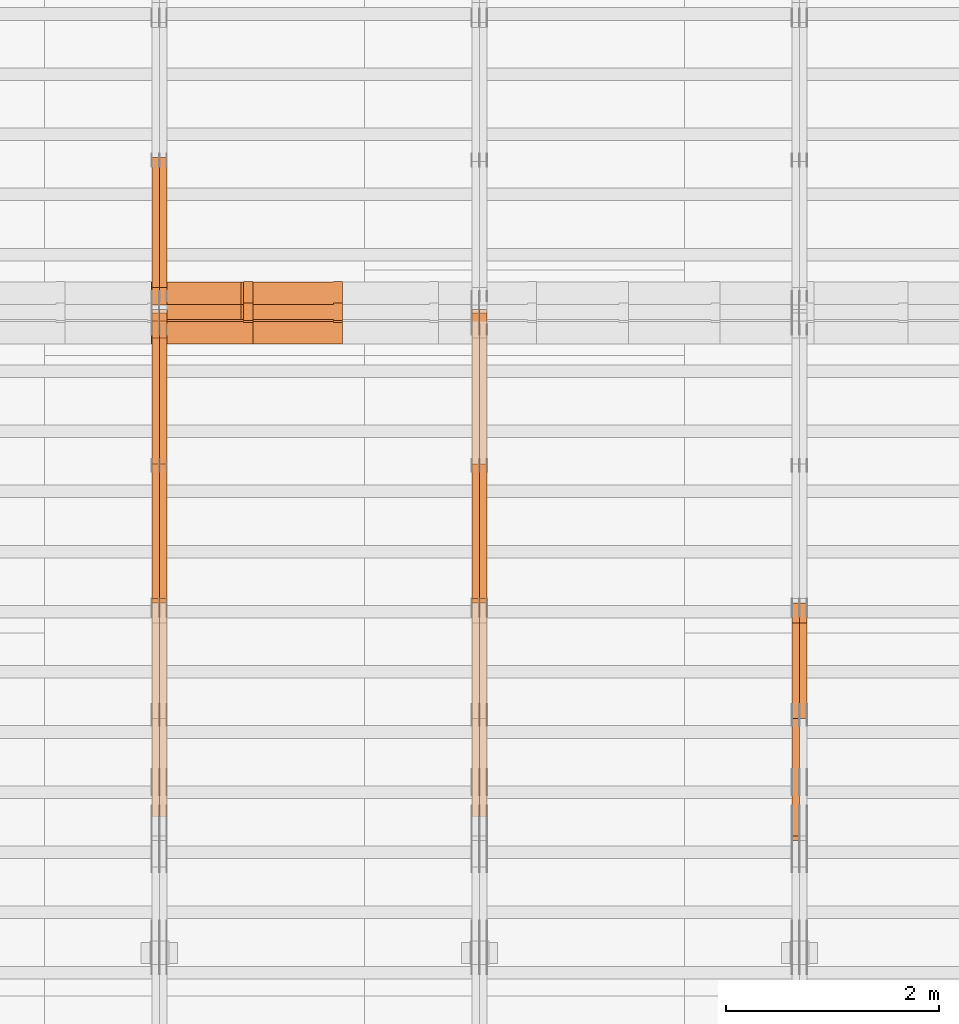
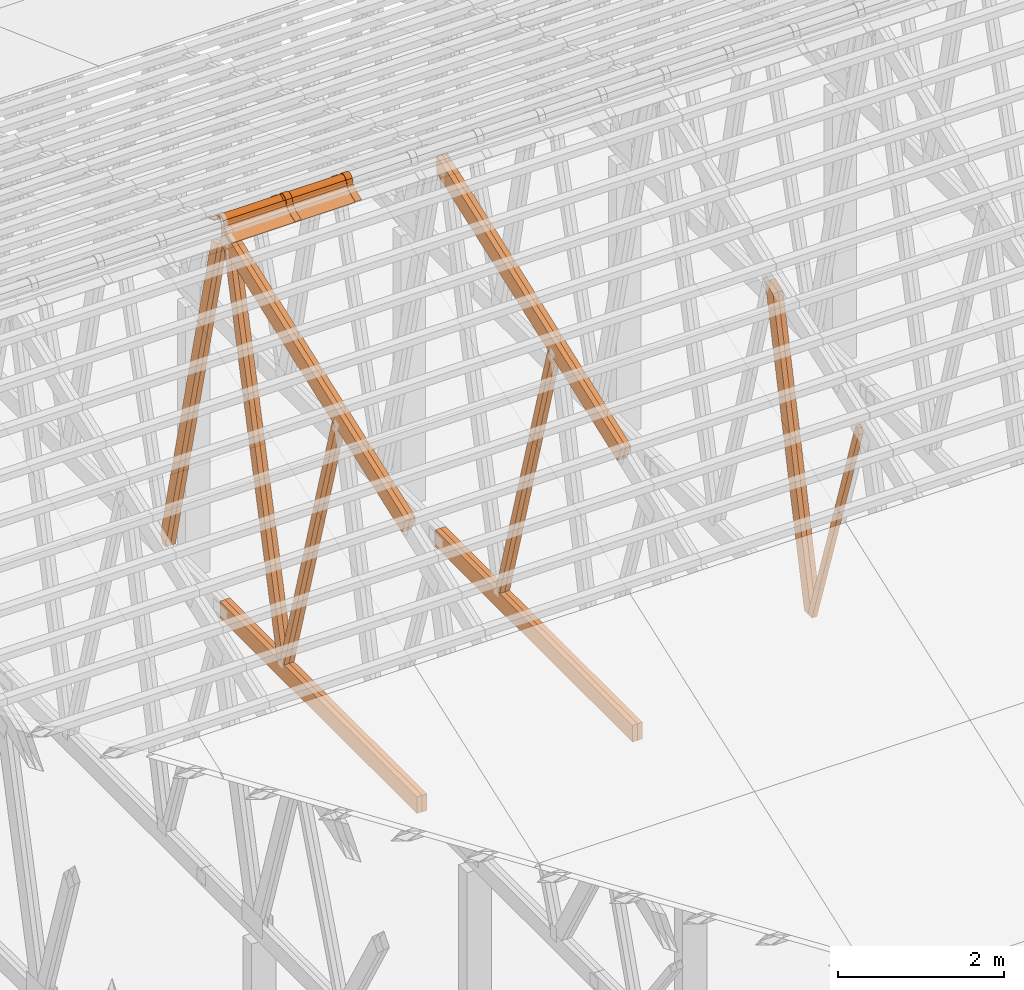
# One storey, part 26 of 189: 23 proxies.
"""IFC2X3 building model written with IfcOpenShell, lengths in millimetres."""

from ifc_helpers import new_model, entity, si_unit, converted_unit, derived_unit, direction, frame, frame_2d, origin, origin_2d_with_axis, place, context, subcontext, project, spatial, polyline, circle_curve, parameter, trimmed, segment, composite_curve, rectangle, outline, extrude, source, transform, mapped, material, type_object, type_shapes, element, save


model = new_model("IFC2X3")

# Units and contexts
model_context = context("Model", 3, precision=0.01, world=origin(), true_north=direction((6.12303176911189e-17, 1.0)))
body_context = subcontext(model_context, "Body", "Model", "MODEL_VIEW")
ifc_project = project(units=[si_unit("LENGTHUNIT", "METRE", prefix="MILLI"), si_unit("AREAUNIT", "SQUARE_METRE"), si_unit("VOLUMEUNIT", "CUBIC_METRE"), converted_unit("PLANEANGLEUNIT", "DEGREE", entity("IfcRatioMeasure", 0.0174532925199433), si_unit("PLANEANGLEUNIT", "RADIAN"), dimensions=[0, 0, 0, 0, 0, 0, 0]), si_unit("MASSUNIT", "GRAM", prefix="KILO"), derived_unit("MASSDENSITYUNIT", [(si_unit("MASSUNIT", "GRAM", prefix="KILO"), 1), (si_unit("LENGTHUNIT", "METRE"), -3)]), si_unit("TIMEUNIT", "SECOND"), si_unit("FREQUENCYUNIT", "HERTZ"), si_unit("THERMODYNAMICTEMPERATUREUNIT", "DEGREE_CELSIUS"), derived_unit("THERMALTRANSMITTANCEUNIT", [(si_unit("MASSUNIT", "GRAM", prefix="KILO"), 1), (si_unit("THERMODYNAMICTEMPERATUREUNIT", "KELVIN"), -1), (si_unit("TIMEUNIT", "SECOND"), -3)]), derived_unit("VOLUMETRICFLOWRATEUNIT", [(si_unit("LENGTHUNIT", "METRE"), 3), (si_unit("TIMEUNIT", "SECOND"), -1)]), si_unit("ELECTRICCURRENTUNIT", "AMPERE"), si_unit("ELECTRICVOLTAGEUNIT", "VOLT"), si_unit("POWERUNIT", "WATT"), si_unit("FORCEUNIT", "NEWTON"), si_unit("ILLUMINANCEUNIT", "LUX"), si_unit("LUMINOUSFLUXUNIT", "LUMEN"), si_unit("LUMINOUSINTENSITYUNIT", "CANDELA"), derived_unit("USERDEFINED", [(si_unit("MASSUNIT", "GRAM", prefix="KILO"), -1), (si_unit("LENGTHUNIT", "METRE"), -2), (si_unit("TIMEUNIT", "SECOND"), 3), (si_unit("LUMINOUSFLUXUNIT", "LUMEN"), 1)]), derived_unit("LINEARVELOCITYUNIT", [(si_unit("LENGTHUNIT", "METRE"), 1), (si_unit("TIMEUNIT", "SECOND"), -1)]), si_unit("PRESSUREUNIT", "PASCAL"), derived_unit("USERDEFINED", [(si_unit("LENGTHUNIT", "METRE"), -2), (si_unit("MASSUNIT", "GRAM", prefix="KILO"), 1), (si_unit("TIMEUNIT", "SECOND"), -2)])], contexts=[model_context])

# Site, building, storey
site_placement = place(None, origin())
site = spatial("IfcSite", under=ifc_project, at=site_placement, CompositionType="ELEMENT")
building_placement = place(site_placement, origin())
building = spatial("IfcBuilding", under=site, at=building_placement, CompositionType="ELEMENT")
storey_placement = place(building_placement, origin())
storey = spatial("IfcBuildingStorey", under=building, at=storey_placement, Name="Default", CompositionType="ELEMENT", Elevation=0.0)

# Proxies
ifc_material_1 = material(Name="IfcSurfaceStyle #115476")
building_element_proxy_type_1 = type_object("IfcBuildingElementProxyType", Name="T1-W3 115474", PredefinedType="NOTDEFINED", material=ifc_material_1)
shared_shape_1 = source(origin(), body_context, "Body", "SweptSolid", [
    extrude(outline(polyline([(-2625.55080717397, -84.9998286237256), (1749.48871563991, -84.9998286237256), (1768.20584427244, 0.000602085469291858), (1625.445846867, 85.0000405971208), (-2517.58959960538, 84.9990145648612), (-2625.55080717397, -84.9998286237256)])), frame((1768.20584427244, 85.0000405971208, 0.0), z_axis=(0.0, 0.0, 1.0), x_axis=(-1.0, 0.0, 0.0)), (0.0, 0.0, 1.0), 69.9999999999997),
])
type_shapes(building_element_proxy_type_1, [shared_shape_1])
proxy_1_placement = place(building_placement, frame((21300.0, 10918.6728403286, 263.278932236374), z_axis=(-1.0, 0.0, 0.0), x_axis=(0.0, 0.215047682154604, 0.976603550269982)))
element("IfcBuildingElementProxy", 1, at=proxy_1_placement, inside=storey, type_object=building_element_proxy_type_1, material=ifc_material_1, Name="T1-W3", context=body_context, shape_type="MappedRepresentation", body=[
    mapped(shared_shape_1, transform((0.0, 0.0, 0.0), scale=1.0)),
])
ifc_material_2 = material(Name="IfcSurfaceStyle #115410")
building_element_proxy_type_2 = type_object("IfcBuildingElementProxyType", Name="T1-W3 115408", PredefinedType="NOTDEFINED", material=ifc_material_2)
shared_shape_2 = source(origin(), body_context, "Body", "SweptSolid", [
    extrude(outline(polyline([(-2625.55080717397, -84.9998286237256), (1749.48871563991, -84.9998286237256), (1768.20584427244, 0.000602085469291858), (1625.445846867, 85.0000405971208), (-2517.58959960538, 84.9990145648612), (-2625.55080717397, -84.9998286237256)])), frame((1768.20584427244, 85.0000405971208, 0.0), z_axis=(0.0, 0.0, 1.0), x_axis=(-1.0, 0.0, 0.0)), (0.0, 0.0, 1.0), 69.9999999999997),
])
type_shapes(building_element_proxy_type_2, [shared_shape_2])
proxy_2_placement = place(building_placement, frame((21230.0, 10918.6728403286, 263.278932236374), z_axis=(-1.0, 0.0, 0.0), x_axis=(0.0, 0.215047682154604, 0.976603550269982)))
element("IfcBuildingElementProxy", 2, at=proxy_2_placement, inside=storey, type_object=building_element_proxy_type_2, material=ifc_material_2, Name="T1-W3", context=body_context, shape_type="MappedRepresentation", body=[
    mapped(shared_shape_2, transform((0.0, 0.0, 0.0), scale=1.0)),
])
ifc_material_3 = material(Name="IfcSurfaceStyle #115146")
building_element_proxy_type_3 = type_object("IfcBuildingElementProxyType", Name="T1-W7 115144", PredefinedType="NOTDEFINED", material=ifc_material_3)
shared_shape_3 = source(origin(), body_context, "Body", "SweptSolid", [
    extrude(outline(polyline([(-2158.15323194511, -47.5001976605119), (1398.58481981178, -47.5001976605119), (1473.93376219819, -0.000131511554346808), (1475.30069254941, 47.5002634162891), (-2189.66604261427, 47.5002634162891), (-2158.15323194511, -47.5001976605119)])), frame((1475.30069254941, 47.5002634162891, 0.0), z_axis=(0.0, 0.0, 1.0), x_axis=(-1.0, 0.0, 0.0)), (0.0, 0.0, 1.0), 69.9999999999998),
])
type_shapes(building_element_proxy_type_3, [shared_shape_3])
proxy_3_placement = place(building_placement, frame((21230.0, 9847.787109375, 3723.57788085937), z_axis=(-1.0, 0.0, 0.0), x_axis=(0.0, 0.314845237923105, -0.949143021971475)))
element("IfcBuildingElementProxy", 3, at=proxy_3_placement, inside=storey, type_object=building_element_proxy_type_3, material=ifc_material_3, Name="T1-W7", context=body_context, shape_type="MappedRepresentation", body=[
    mapped(shared_shape_3, transform((0.0, 0.0, 0.0), scale=1.0)),
])
ifc_material_4 = material(Name="IfcSurfaceStyle #99950")
building_element_proxy_type_4 = type_object("IfcBuildingElementProxyType", Name="T1-W6 99948", PredefinedType="NOTDEFINED", material=ifc_material_4)
shared_shape_4 = source(origin(), body_context, "Body", "SweptSolid", [
    extrude(outline(polyline([(-2640.84340836012, -47.4996765865792), (1711.12245024294, -47.4996765865792), (1797.68490303083, -9.57690019346202e-05), (1800.72595169379, 47.4997244710801), (-2668.68989660745, 47.4997244710801), (-2640.84340836012, -47.4996765865792)])), frame((1800.72595169379, 47.5003009358159, 0.0), z_axis=(0.0, 0.0, 1.0), x_axis=(-1.0, 0.0, 0.0)), (0.0, 0.0, 1.0), 69.9999999999997),
])
type_shapes(building_element_proxy_type_4, [shared_shape_4])
proxy_4_placement = place(building_placement, frame((18300.0, 12074.2896156894, 4533.9586582452), z_axis=(-1.0, 0.0, 0.0), x_axis=(0.0, 0.28128598310461, -0.959623986626467)))
element("IfcBuildingElementProxy", 4, at=proxy_4_placement, inside=storey, type_object=building_element_proxy_type_4, material=ifc_material_4, Name="T1-W6", context=body_context, shape_type="MappedRepresentation", body=[
    mapped(shared_shape_4, transform((0.0, 0.0, 0.0), scale=1.0)),
])
ifc_material_5 = material(Name="IfcSurfaceStyle #99884")
building_element_proxy_type_5 = type_object("IfcBuildingElementProxyType", Name="T1-W6 99882", PredefinedType="NOTDEFINED", material=ifc_material_5)
shared_shape_5 = source(origin(), body_context, "Body", "SweptSolid", [
    extrude(outline(polyline([(-2640.84340836012, -47.4996765865792), (1711.12245024294, -47.4996765865792), (1797.68490303083, -9.57690019346202e-05), (1800.72595169379, 47.4997244710801), (-2668.68989660745, 47.4997244710801), (-2640.84340836012, -47.4996765865792)])), frame((1800.72595169379, 47.5003009358159, 0.0), z_axis=(0.0, 0.0, 1.0), x_axis=(-1.0, 0.0, 0.0)), (0.0, 0.0, 1.0), 69.9999999999997),
])
type_shapes(building_element_proxy_type_5, [shared_shape_5])
proxy_5_placement = place(building_placement, frame((18230.0, 12074.2896156894, 4533.9586582452), z_axis=(-1.0, 0.0, 0.0), x_axis=(0.0, 0.28128598310461, -0.959623986626467)))
element("IfcBuildingElementProxy", 5, at=proxy_5_placement, inside=storey, type_object=building_element_proxy_type_5, material=ifc_material_5, Name="T1-W6", context=body_context, shape_type="MappedRepresentation", body=[
    mapped(shared_shape_5, transform((0.0, 0.0, 0.0), scale=1.0)),
])
ifc_material_6 = material(Name="IfcSurfaceStyle #95930")
building_element_proxy_type_6 = type_object("IfcBuildingElementProxyType", Name="T1-B3 95928", PredefinedType="NOTDEFINED", material=ifc_material_6)
shared_shape_6 = source(origin(), body_context, "Body", "SweptSolid", [
    extrude(rectangle(XDim=4751.0283203125, YDim=245.000000000001, at=origin_2d_with_axis()), frame((2375.51416015625, 122.5, 0.0), z_axis=(0.0, 0.0, 1.0), x_axis=(-1.0, 0.0, 0.0)), (0.0, 0.0, 1.0), 69.9999999999997),
])
type_shapes(building_element_proxy_type_6, [shared_shape_6])
proxy_6_placement = place(building_placement, frame((18300.0, 10029.23046875, 245.0), z_axis=(-1.0, 0.0, 0.0), x_axis=(0.0, 1.0, 0.0)))
element("IfcBuildingElementProxy", 6, at=proxy_6_placement, inside=storey, type_object=building_element_proxy_type_6, material=ifc_material_6, Name="T1-B3", context=body_context, shape_type="MappedRepresentation", body=[
    mapped(shared_shape_6, transform((0.0, 0.0, 0.0), scale=1.0)),
])
ifc_material_7 = material(Name="IfcSurfaceStyle #95873")
building_element_proxy_type_7 = type_object("IfcBuildingElementProxyType", Name="T1-B3 95871", PredefinedType="NOTDEFINED", material=ifc_material_7)
shared_shape_7 = source(origin(), body_context, "Body", "SweptSolid", [
    extrude(rectangle(XDim=4751.0283203125, YDim=245.000000000001, at=origin_2d_with_axis()), frame((2375.51416015625, 122.5, 0.0), z_axis=(0.0, 0.0, 1.0), x_axis=(-1.0, 0.0, 0.0)), (0.0, 0.0, 1.0), 69.9999999999997),
])
type_shapes(building_element_proxy_type_7, [shared_shape_7])
proxy_7_placement = place(building_placement, frame((18230.0, 10029.23046875, 245.0), z_axis=(-1.0, 0.0, 0.0), x_axis=(0.0, 1.0, 0.0)))
element("IfcBuildingElementProxy", 7, at=proxy_7_placement, inside=storey, type_object=building_element_proxy_type_7, material=ifc_material_7, Name="T1-B3", context=body_context, shape_type="MappedRepresentation", body=[
    mapped(shared_shape_7, transform((0.0, 0.0, 0.0), scale=1.0)),
])
ifc_material_8 = material(Name="IfcSurfaceStyle #95342")
building_element_proxy_type_8 = type_object("IfcBuildingElementProxyType", Name="T1-T3 95340", PredefinedType="NOTDEFINED", material=ifc_material_8)
shared_shape_8 = source(origin(), body_context, "Body", "SweptSolid", [
    extrude(outline(polyline([(-2341.64890001385, -122.499972785692), (2386.23525922045, -122.499972785692), (2297.06252495753, 122.499972785692), (-2341.64888416412, 122.499972785692), (-2341.64890001385, -122.499972785692)])), frame((2386.23525922045, 122.499973888764, 0.0), z_axis=(0.0, 0.0, 1.0), x_axis=(-1.0, 0.0, 0.0)), (0.0, 0.0, 1.0), 69.9999999999997),
])
type_shapes(building_element_proxy_type_8, [shared_shape_8])
proxy_8_placement = place(building_placement, frame((18300.0, 14833.7949607394, 5538.33627266055), z_axis=(-1.0, 0.0, 0.0), x_axis=(0.0, -0.939692620785908, -0.342020143325669)))
element("IfcBuildingElementProxy", 8, at=proxy_8_placement, inside=storey, type_object=building_element_proxy_type_8, material=ifc_material_8, Name="T1-T3", context=body_context, shape_type="MappedRepresentation", body=[
    mapped(shared_shape_8, transform((0.0, 0.0, 0.0), scale=1.0)),
])
ifc_material_9 = material(Name="IfcSurfaceStyle #95285")
building_element_proxy_type_9 = type_object("IfcBuildingElementProxyType", Name="T1-T3 95283", PredefinedType="NOTDEFINED", material=ifc_material_9)
shared_shape_9 = source(origin(), body_context, "Body", "SweptSolid", [
    extrude(outline(polyline([(-2341.64890001385, -122.499972785692), (2386.23525922045, -122.499972785692), (2297.06252495753, 122.499972785692), (-2341.64888416412, 122.499972785692), (-2341.64890001385, -122.499972785692)])), frame((2386.23525922045, 122.499973888764, 0.0), z_axis=(0.0, 0.0, 1.0), x_axis=(-1.0, 0.0, 0.0)), (0.0, 0.0, 1.0), 69.9999999999997),
])
type_shapes(building_element_proxy_type_9, [shared_shape_9])
proxy_9_placement = place(building_placement, frame((18230.0, 14833.7949607394, 5538.33627266055), z_axis=(-1.0, 0.0, 0.0), x_axis=(0.0, -0.939692620785908, -0.342020143325669)))
element("IfcBuildingElementProxy", 9, at=proxy_9_placement, inside=storey, type_object=building_element_proxy_type_9, material=ifc_material_9, Name="T1-T3", context=body_context, shape_type="MappedRepresentation", body=[
    mapped(shared_shape_9, transform((0.0, 0.0, 0.0), scale=1.0)),
])
ifc_material_10 = material(Name="IfcSurfaceStyle #84424")
building_element_proxy_type_10 = type_object("IfcBuildingElementProxyType", Name="T1-W5 84422", PredefinedType="NOTDEFINED", material=ifc_material_10)
shared_shape_10 = source(origin(), body_context, "Body", "SweptSolid", [
    extrude(outline(polyline([(-3233.61216530572, -72.4999091305202), (2153.79187521892, -72.4999091305202), (2171.36968478227, -7.18521572819375e-05), (2045.62106208646, 72.4999450565989), (-3137.17045678193, 72.4999450565989), (-3233.61216530572, -72.4999091305202)])), frame((2171.36968478227, 72.500192121173, 0.0), z_axis=(0.0, 0.0, 1.0), x_axis=(-1.0, 0.0, 0.0)), (0.0, 0.0, 1.0), 69.9999999999997),
])
type_shapes(building_element_proxy_type_10, [shared_shape_10])
proxy_10_placement = place(building_placement, frame((15300.0, 13261.0146935344, 262.082919891325), z_axis=(-1.0, 0.0, 0.0), x_axis=(0.0, 0.235625623344066, 0.97184389982328)))
element("IfcBuildingElementProxy", 10, at=proxy_10_placement, inside=storey, type_object=building_element_proxy_type_10, material=ifc_material_10, Name="T1-W5", context=body_context, shape_type="MappedRepresentation", body=[
    mapped(shared_shape_10, transform((0.0, 0.0, 0.0), scale=1.0)),
])
ifc_material_11 = material(Name="IfcSurfaceStyle #84358")
building_element_proxy_type_11 = type_object("IfcBuildingElementProxyType", Name="T1-W5 84356", PredefinedType="NOTDEFINED", material=ifc_material_11)
shared_shape_11 = source(origin(), body_context, "Body", "SweptSolid", [
    extrude(outline(polyline([(-3233.61216530572, -72.4999091305202), (2153.79187521892, -72.4999091305202), (2171.36968478227, -7.18521572819375e-05), (2045.62106208646, 72.4999450565989), (-3137.17045678193, 72.4999450565989), (-3233.61216530572, -72.4999091305202)])), frame((2171.36968478227, 72.500192121173, 0.0), z_axis=(0.0, 0.0, 1.0), x_axis=(-1.0, 0.0, 0.0)), (0.0, 0.0, 1.0), 69.9999999999997),
])
type_shapes(building_element_proxy_type_11, [shared_shape_11])
proxy_11_placement = place(building_placement, frame((15230.0, 13261.0146935344, 262.082919891325), z_axis=(-1.0, 0.0, 0.0), x_axis=(0.0, 0.235625623344066, 0.97184389982328)))
element("IfcBuildingElementProxy", 11, at=proxy_11_placement, inside=storey, type_object=building_element_proxy_type_11, material=ifc_material_11, Name="T1-W5", context=body_context, shape_type="MappedRepresentation", body=[
    mapped(shared_shape_11, transform((0.0, 0.0, 0.0), scale=1.0)),
])
ifc_material_12 = material(Name="IfcSurfaceStyle #84292")
building_element_proxy_type_12 = type_object("IfcBuildingElementProxyType", Name="T1-W5 84290", PredefinedType="NOTDEFINED", material=ifc_material_12)
shared_shape_12 = source(origin(), body_context, "Body", "SweptSolid", [
    extrude(outline(polyline([(-3137.17045678193, -72.5002081306407), (2045.62106208646, -72.5002081306408), (2171.36968478227, 5.58426931168476e-05), (2153.79187521892, 72.5001802092942), (-3233.61216530572, 72.5001802092942), (-3137.17045678193, -72.5002081306407)])), frame((2171.36968478227, 72.5001802092942, 0.0), z_axis=(0.0, 0.0, 1.0), x_axis=(-1.0, 0.0, 0.0)), (0.0, 0.0, 1.0), 69.9999999999997),
])
type_shapes(building_element_proxy_type_12, [shared_shape_12])
proxy_12_placement = place(building_placement, frame((15300.0, 16098.0675635854, 227.917113003597), z_axis=(-1.0, 0.0, 0.0), x_axis=(0.0, -0.235625623344066, 0.971843899823279)))
element("IfcBuildingElementProxy", 12, at=proxy_12_placement, inside=storey, type_object=building_element_proxy_type_12, material=ifc_material_12, Name="T1-W5", context=body_context, shape_type="MappedRepresentation", body=[
    mapped(shared_shape_12, transform((0.0, 0.0, 0.0), scale=1.0)),
])
ifc_material_13 = material(Name="IfcSurfaceStyle #84226")
building_element_proxy_type_13 = type_object("IfcBuildingElementProxyType", Name="T1-W5 84224", PredefinedType="NOTDEFINED", material=ifc_material_13)
shared_shape_13 = source(origin(), body_context, "Body", "SweptSolid", [
    extrude(outline(polyline([(-3137.17045678193, -72.5002081306407), (2045.62106208646, -72.5002081306408), (2171.36968478227, 5.58426931168476e-05), (2153.79187521892, 72.5001802092942), (-3233.61216530572, 72.5001802092942), (-3137.17045678193, -72.5002081306407)])), frame((2171.36968478227, 72.5001802092942, 0.0), z_axis=(0.0, 0.0, 1.0), x_axis=(-1.0, 0.0, 0.0)), (0.0, 0.0, 1.0), 69.9999999999997),
])
type_shapes(building_element_proxy_type_13, [shared_shape_13])
proxy_13_placement = place(building_placement, frame((15230.0, 16098.0675635854, 227.917113003597), z_axis=(-1.0, 0.0, 0.0), x_axis=(0.0, -0.235625623344066, 0.971843899823279)))
element("IfcBuildingElementProxy", 13, at=proxy_13_placement, inside=storey, type_object=building_element_proxy_type_13, material=ifc_material_13, Name="T1-W5", context=body_context, shape_type="MappedRepresentation", body=[
    mapped(shared_shape_13, transform((0.0, 0.0, 0.0), scale=1.0)),
])
ifc_material_14 = material(Name="IfcSurfaceStyle #84160")
building_element_proxy_type_14 = type_object("IfcBuildingElementProxyType", Name="T1-W6 84158", PredefinedType="NOTDEFINED", material=ifc_material_14)
shared_shape_14 = source(origin(), body_context, "Body", "SweptSolid", [
    extrude(outline(polyline([(-2640.84340836012, -47.4996765865792), (1711.12245024294, -47.4996765865792), (1797.68490303083, -9.57690019346202e-05), (1800.72595169379, 47.4997244710801), (-2668.68989660745, 47.4997244710801), (-2640.84340836012, -47.4996765865792)])), frame((1800.72595169379, 47.5003009358159, 0.0), z_axis=(0.0, 0.0, 1.0), x_axis=(-1.0, 0.0, 0.0)), (0.0, 0.0, 1.0), 69.9999999999997),
])
type_shapes(building_element_proxy_type_14, [shared_shape_14])
proxy_14_placement = place(building_placement, frame((15300.0, 12074.2896156894, 4533.9586582452), z_axis=(-1.0, 0.0, 0.0), x_axis=(0.0, 0.28128598310461, -0.959623986626467)))
element("IfcBuildingElementProxy", 14, at=proxy_14_placement, inside=storey, type_object=building_element_proxy_type_14, material=ifc_material_14, Name="T1-W6", context=body_context, shape_type="MappedRepresentation", body=[
    mapped(shared_shape_14, transform((0.0, 0.0, 0.0), scale=1.0)),
])
ifc_material_15 = material(Name="IfcSurfaceStyle #84094")
building_element_proxy_type_15 = type_object("IfcBuildingElementProxyType", Name="T1-W6 84092", PredefinedType="NOTDEFINED", material=ifc_material_15)
shared_shape_15 = source(origin(), body_context, "Body", "SweptSolid", [
    extrude(outline(polyline([(-2640.84340836012, -47.4996765865792), (1711.12245024294, -47.4996765865792), (1797.68490303083, -9.57690019346202e-05), (1800.72595169379, 47.4997244710801), (-2668.68989660745, 47.4997244710801), (-2640.84340836012, -47.4996765865792)])), frame((1800.72595169379, 47.5003009358159, 0.0), z_axis=(0.0, 0.0, 1.0), x_axis=(-1.0, 0.0, 0.0)), (0.0, 0.0, 1.0), 69.9999999999997),
])
type_shapes(building_element_proxy_type_15, [shared_shape_15])
proxy_15_placement = place(building_placement, frame((15230.0, 12074.2896156894, 4533.9586582452), z_axis=(-1.0, 0.0, 0.0), x_axis=(0.0, 0.28128598310461, -0.959623986626467)))
element("IfcBuildingElementProxy", 15, at=proxy_15_placement, inside=storey, type_object=building_element_proxy_type_15, material=ifc_material_15, Name="T1-W6", context=body_context, shape_type="MappedRepresentation", body=[
    mapped(shared_shape_15, transform((0.0, 0.0, 0.0), scale=1.0)),
])
ifc_material_16 = material(Name="IfcSurfaceStyle #80140")
building_element_proxy_type_16 = type_object("IfcBuildingElementProxyType", Name="T1-B3 80138", PredefinedType="NOTDEFINED", material=ifc_material_16)
shared_shape_16 = source(origin(), body_context, "Body", "SweptSolid", [
    extrude(rectangle(XDim=4751.0283203125, YDim=245.000000000001, at=origin_2d_with_axis()), frame((2375.51416015625, 122.5, 0.0), z_axis=(0.0, 0.0, 1.0), x_axis=(-1.0, 0.0, 0.0)), (0.0, 0.0, 1.0), 69.9999999999997),
])
type_shapes(building_element_proxy_type_16, [shared_shape_16])
proxy_16_placement = place(building_placement, frame((15300.0, 10029.23046875, 245.0), z_axis=(-1.0, 0.0, 0.0), x_axis=(0.0, 1.0, 0.0)))
element("IfcBuildingElementProxy", 16, at=proxy_16_placement, inside=storey, type_object=building_element_proxy_type_16, material=ifc_material_16, Name="T1-B3", context=body_context, shape_type="MappedRepresentation", body=[
    mapped(shared_shape_16, transform((0.0, 0.0, 0.0), scale=1.0)),
])
ifc_material_17 = material(Name="IfcSurfaceStyle #80083")
building_element_proxy_type_17 = type_object("IfcBuildingElementProxyType", Name="T1-B3 80081", PredefinedType="NOTDEFINED", material=ifc_material_17)
shared_shape_17 = source(origin(), body_context, "Body", "SweptSolid", [
    extrude(rectangle(XDim=4751.0283203125, YDim=245.000000000001, at=origin_2d_with_axis()), frame((2375.51416015625, 122.5, 0.0), z_axis=(0.0, 0.0, 1.0), x_axis=(-1.0, 0.0, 0.0)), (0.0, 0.0, 1.0), 69.9999999999997),
])
type_shapes(building_element_proxy_type_17, [shared_shape_17])
proxy_17_placement = place(building_placement, frame((15230.0, 10029.23046875, 245.0), z_axis=(-1.0, 0.0, 0.0), x_axis=(0.0, 1.0, 0.0)))
element("IfcBuildingElementProxy", 17, at=proxy_17_placement, inside=storey, type_object=building_element_proxy_type_17, material=ifc_material_17, Name="T1-B3", context=body_context, shape_type="MappedRepresentation", body=[
    mapped(shared_shape_17, transform((0.0, 0.0, 0.0), scale=1.0)),
])
ifc_material_18 = material(Name="IfcSurfaceStyle #79552")
building_element_proxy_type_18 = type_object("IfcBuildingElementProxyType", Name="T1-T3 79550", PredefinedType="NOTDEFINED", material=ifc_material_18)
shared_shape_18 = source(origin(), body_context, "Body", "SweptSolid", [
    extrude(outline(polyline([(-2341.64890001385, -122.499972785692), (2386.23525922045, -122.499972785692), (2297.06252495753, 122.499972785692), (-2341.64888416412, 122.499972785692), (-2341.64890001385, -122.499972785692)])), frame((2386.23525922045, 122.499973888764, 0.0), z_axis=(0.0, 0.0, 1.0), x_axis=(-1.0, 0.0, 0.0)), (0.0, 0.0, 1.0), 69.9999999999997),
])
type_shapes(building_element_proxy_type_18, [shared_shape_18])
proxy_18_placement = place(building_placement, frame((15300.0, 14833.7949607394, 5538.33627266055), z_axis=(-1.0, 0.0, 0.0), x_axis=(0.0, -0.939692620785908, -0.342020143325669)))
element("IfcBuildingElementProxy", 18, at=proxy_18_placement, inside=storey, type_object=building_element_proxy_type_18, material=ifc_material_18, Name="T1-T3", context=body_context, shape_type="MappedRepresentation", body=[
    mapped(shared_shape_18, transform((0.0, 0.0, 0.0), scale=1.0)),
])
ifc_material_19 = material(Name="IfcSurfaceStyle #79495")
building_element_proxy_type_19 = type_object("IfcBuildingElementProxyType", Name="T1-T3 79493", PredefinedType="NOTDEFINED", material=ifc_material_19)
shared_shape_19 = source(origin(), body_context, "Body", "SweptSolid", [
    extrude(outline(polyline([(-2341.64890001385, -122.499972785692), (2386.23525922045, -122.499972785692), (2297.06252495753, 122.499972785692), (-2341.64888416412, 122.499972785692), (-2341.64890001385, -122.499972785692)])), frame((2386.23525922045, 122.499973888764, 0.0), z_axis=(0.0, 0.0, 1.0), x_axis=(-1.0, 0.0, 0.0)), (0.0, 0.0, 1.0), 69.9999999999997),
])
type_shapes(building_element_proxy_type_19, [shared_shape_19])
proxy_19_placement = place(building_placement, frame((15230.0, 14833.7949607394, 5538.33627266055), z_axis=(-1.0, 0.0, 0.0), x_axis=(0.0, -0.939692620785908, -0.342020143325669)))
element("IfcBuildingElementProxy", 19, at=proxy_19_placement, inside=storey, type_object=building_element_proxy_type_19, material=ifc_material_19, Name="T1-T3", context=body_context, shape_type="MappedRepresentation", body=[
    mapped(shared_shape_19, transform((0.0, 0.0, 0.0), scale=1.0)),
])
ifc_material_20 = material()
building_element_proxy_type_20 = type_object("IfcBuildingElementProxyType", Name="P75", PredefinedType="NOTDEFINED", material=ifc_material_20)
shared_shape_20 = source(origin(), body_context, "Body", "SweptSolid", [
    extrude(outline(composite_curve([segment(polyline([(-69.4623915065845, -4.60763114971976), (47.4521071665907, -4.60763114971981)]), True, "CONTINUOUS"), segment(trimmed(circle_curve(frame_2d((119.940978060963, 14.6372018310859), x_axis=(-0.966518278591622, -0.256597773077395)), 75.0), [parameter(6.61555373744412e-13)], [parameter(180.0)], True, "PARAMETER"), True, "CONTINUOUS"), segment(polyline([(192.429848955335, 33.882034811891), (182.764666169419, 31.3160570811166)]), True, "CONTINUOUS"), segment(trimmed(circle_curve(frame_2d((119.940978060963, 14.6372018310859), x_axis=(-0.966518278591622, -0.256597773077395)), 65.0), [parameter(1.06866637297174e-12)], [parameter(180.0)], True, "PARAMETER"), False, "CONTINUOUS"), segment(polyline([(57.1172899525073, -2.04165341894578), (47.4521071665911, 5.39236885028051)]), True, "CONTINUOUS"), segment(polyline([(47.4521071665911, 5.39236885028052), (-70.7672243976422, 5.39236885028094)]), True, "CONTINUOUS"), segment(polyline([(-70.7672243976422, 5.39236885028094), (-194.776190618495, -27.5303655446341)]), True, "CONTINUOUS"), segment(polyline([(-194.776190618495, -27.5303655446341), (-192.210212887721, -37.1955483305503)]), True, "CONTINUOUS"), segment(polyline([(-192.210212887721, -37.1955483305503), (-69.4623915065845, -4.60763114971974)]), True, "CONTINUOUS")], self_intersect=False)), frame((0.0, 106.775760402721, -56.5599052870917), z_axis=(1.0, 0.0, 0.0), x_axis=(0.0, -0.820468487122275, 0.571691754041709)), (0.0, 0.0, 1.0), 867.000000000001),
    extrude(outline(composite_curve([segment(polyline([(62.2906866429439, -18.428943356533), (189.290686642944, -18.428943356533)]), True, "CONTINUOUS"), segment(polyline([(189.290686642944, -18.428943356533), (189.290686642944, -8.42894335653292)]), True, "CONTINUOUS"), segment(polyline([(189.290686642944, -8.42894335653292), (62.2906866429439, -8.42894335653294)]), True, "CONTINUOUS"), segment(polyline([(62.2906866429439, -8.42894335653294), (-41.0348065006093, 19.0026034957362)]), True, "CONTINUOUS"), segment(trimmed(circle_curve(frame_2d((-125.709313357056, 11.5710566434651), x_axis=(1.0, 0.0)), 85.0), [parameter(5.01577186738723)], [parameter(180.0)], True, "PARAMETER"), True, "CONTINUOUS"), segment(polyline([(-210.709313357056, 11.5710566434656), (-200.709313357056, 11.5710566434656)]), True, "CONTINUOUS"), segment(trimmed(circle_curve(frame_2d((-125.709313357056, 11.5710566434651), x_axis=(1.0, 0.0)), 75.0), [parameter(3.05333249420498e-13)], [parameter(180.0)], True, "PARAMETER"), False, "CONTINUOUS"), segment(polyline([(-50.7093133570542, 11.5710566434655), (62.290686642944, -18.4289433565322)]), True, "CONTINUOUS")], self_intersect=False)), frame((867.0, 114.170579674061, -53.8683539143053), z_axis=(1.0, 0.0, 0.0), x_axis=(0.0, 0.939692620785914, -0.342020143325653)), (0.0, 0.0, 1.0), 86.9999999999998),
])
type_shapes(building_element_proxy_type_20, [shared_shape_20])
for number, where, name in (
    (20, (15992.9353253273, 14755.0000438631, 5865.69618295448), "P75, generic model20:P75"),
    (21, (15152.9353253273, 14755.0000438631, 5865.69618295448), "P75, generic model20:P75"),
):
    element("IfcBuildingElementProxy", number, at=place(storey_placement, frame(where)), inside=storey, type_object=building_element_proxy_type_20, material=ifc_material_20, Name=name, ObjectType="P75, generic model20:P75", context=body_context, shape_type="MappedRepresentation", body=[
        mapped(shared_shape_20, transform((0.0, 0.0, 0.0), scale=1.0)),
    ])
building_element_proxy_type_21 = type_object("IfcBuildingElementProxyType", Name="P75", PredefinedType="NOTDEFINED", material=ifc_material_20)
shared_shape_21 = source(origin(), body_context, "Body", "SweptSolid", [
    extrude(outline(composite_curve([segment(polyline([(68.3189789579817, 13.3705352460084), (195.318978957982, 13.3705352460084)]), True, "CONTINUOUS"), segment(polyline([(195.318978957982, 13.3705352460084), (195.318978957982, 23.3705352460084)]), True, "CONTINUOUS"), segment(polyline([(195.318978957982, 23.3705352460084), (67.014146066922, 23.3705352460088)]), True, "CONTINUOUS"), segment(polyline([(67.014146066922, 23.3705352460088), (-47.2469987727929, -6.96428196807339)]), True, "CONTINUOUS"), segment(polyline([(-47.2469987727929, -6.96428196807339), (-54.6810210420187, -16.62946475399)]), True, "CONTINUOUS"), segment(trimmed(circle_curve(frame_2d((-119.681021042019, -16.6294647539896), x_axis=(1.0, 0.0)), 65.0), [parameter(180.0)], [parameter(359.999999999999)], True, "PARAMETER"), False, "CONTINUOUS"), segment(polyline([(-184.681021042019, -16.6294647539905), (-194.681021042019, -16.6294647539901)]), True, "CONTINUOUS"), segment(trimmed(circle_curve(frame_2d((-119.681021042019, -16.6294647539896), x_axis=(1.0, 0.0)), 75.0), [parameter(180.0)], [parameter(359.999999999999)], True, "PARAMETER"), True, "CONTINUOUS"), segment(polyline([(-44.6810210420183, -16.6294647539898), (68.3189789579816, 13.3705352460083)]), True, "CONTINUOUS")], self_intersect=False)), frame((0.0, -106.775760402721, -56.5599052870916), z_axis=(1.0, 0.0, 0.0), x_axis=(0.0, -0.939692620785914, -0.342020143325654)), (0.0, 0.0, 1.0), 867.000000000001),
    extrude(outline(composite_curve([segment(polyline([(-64.9339130518847, 1.82825913317695), (-187.681734433021, -30.7596580476538)]), True, "CONTINUOUS"), segment(polyline([(-187.681734433021, -30.7596580476538), (-185.115756702247, -40.4248408335702)]), True, "CONTINUOUS"), segment(polyline([(-185.115756702247, -40.4248408335702), (-62.3679353211107, -7.83692365273935)]), True, "CONTINUOUS"), segment(polyline([(-62.3679353211107, -7.83692365273935), (44.5369162809878, -7.83692365273935)]), True, "CONTINUOUS"), segment(trimmed(circle_curve(frame_2d((124.469456515662, 21.0730921139827), x_axis=(-0.966518278591636, -0.256597773077402)), 85.0), [parameter(5.01577186738723)], [parameter(180.0)], True, "PARAMETER"), True, "CONTINUOUS"), segment(polyline([(206.623510195951, 42.8839028255618), (196.958327410034, 40.3179250947878)]), True, "CONTINUOUS"), segment(trimmed(circle_curve(frame_2d((124.469456515662, 21.0730921139827), x_axis=(-0.966518278591636, -0.256597773077402)), 75.0), [parameter(3.05333249420498e-13)], [parameter(180.0)], True, "PARAMETER"), False, "CONTINUOUS"), segment(polyline([(51.9805856212887, 1.82825913317622), (-64.9339130518846, 1.82825913317621)]), True, "CONTINUOUS")], self_intersect=False)), frame((867.0, -114.170579674061, -53.868353914305), z_axis=(-1.0, 0.0, 0.0), x_axis=(0.0, 0.820468487122275, 0.571691754041709)), (0.0, 0.0, -1.0), 86.9999999999998),
])
type_shapes(building_element_proxy_type_21, [shared_shape_21])
for number, where, name in (
    (22, (15992.9353253273, 14745.0000384614, 5850.69618295448), "P75, generic model20:P75"),
    (23, (15152.9353253273, 14745.0000384614, 5850.69618295448), "P75, generic model20:P75"),
):
    element("IfcBuildingElementProxy", number, at=place(storey_placement, frame(where)), inside=storey, type_object=building_element_proxy_type_21, material=ifc_material_20, Name=name, ObjectType="P75, generic model20:P75", context=body_context, shape_type="MappedRepresentation", body=[
        mapped(shared_shape_21, transform((0.0, 0.0, 0.0), scale=1.0)),
    ])

save(model, "model.ifc")
